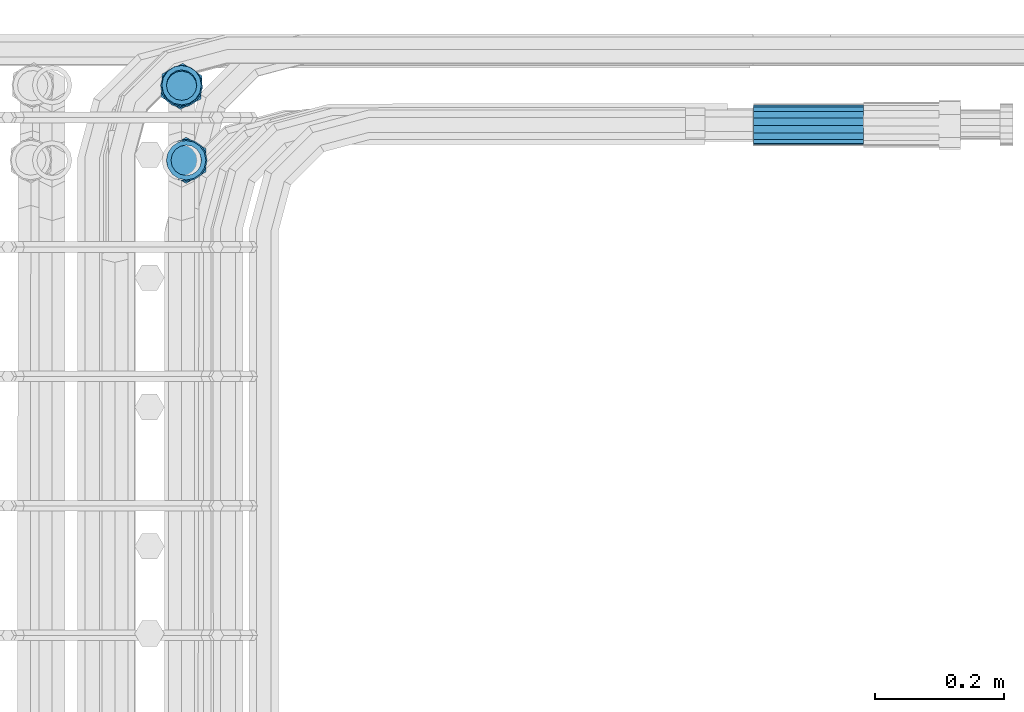
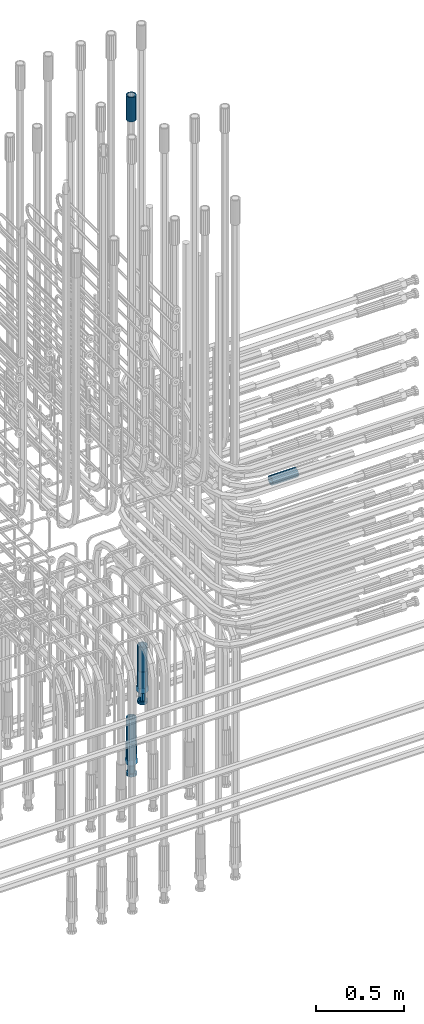
# One storey, part 108 of 177: 6 beams.
"""IFC2X3 building model written with IfcOpenShell, lengths in millimetres."""

from ifc_helpers import new_model, si_unit, frame, origin_with_axes, place, context, subcontext, project, spatial, faceted_brep, material, type_object, element, save


model = new_model("IFC2X3")

# Units and contexts
model_context_1 = context("Model", 3, precision=1e-05, world=origin_with_axes())
model_context_2 = context("Model", 3, precision=1e-05, world=origin_with_axes())
body_context = subcontext(model_context_2, "Body", "Model", "MODEL_VIEW")
ifc_project = project(units=[si_unit("LENGTHUNIT", "METRE", prefix="MILLI"), si_unit("AREAUNIT", "SQUARE_METRE"), si_unit("VOLUMEUNIT", "CUBIC_METRE"), si_unit("MASSUNIT", "GRAM", prefix="KILO"), si_unit("TIMEUNIT", "SECOND"), si_unit("PLANEANGLEUNIT", "RADIAN"), si_unit("SOLIDANGLEUNIT", "STERADIAN"), si_unit("THERMODYNAMICTEMPERATUREUNIT", "DEGREE_CELSIUS"), si_unit("LUMINOUSINTENSITYUNIT", "LUMEN")], contexts=[model_context_1])

# Site, building, storey
site_placement = place(None, origin_with_axes())
site = spatial("IfcSite", under=ifc_project, at=site_placement, CompositionType="ELEMENT")
building_placement = place(site_placement, origin_with_axes())
building = spatial("IfcBuilding", under=site, at=building_placement, Name="Undefined", CompositionType="ELEMENT")
storey_placement = place(building_placement, origin_with_axes())
storey = spatial("IfcBuildingStorey", under=building, at=storey_placement, Name="Undefined", CompositionType="ELEMENT", Elevation=0.0)

# Beams
ifc_material = material(Name="STEEL/S275")
beam_type_1 = type_object("IfcBeamType", PredefinedType="NOTDEFINED")
beam_1_placement = place(storey_placement, frame((2038719.51584447, 6206284.09877293, 19865.9276902425), z_axis=(0.0, 0.0401317930035295, -0.99919439509553), x_axis=(1.0, 0.0, 0.0)))
element("IfcBeam", 1, at=beam_1_placement, inside=storey, type_object=beam_type_1, material=ifc_material, Name="AG40N", context=body_context, shape_type="Brep", body=[
    faceted_brep([(0.0, -23.5000000001164, -9.31322574615479e-10), (0.0, -21.7111690140155, 8.99306066054851), (170.0, -21.7111690140155, 8.99306066054851), (170.0, -23.5, 0.0), (0.0, -16.6170093578839, 16.6170093575493), (170.0, -16.6170093578839, 16.6170093575493), (0.0, -8.99306066057943, 21.7111690137535), (170.0, -8.99306066057943, 21.7111690137535), (0.0, 1.16415321826935e-10, 23.5), (170.0, 0.0, 23.5), (0.0, 8.99306066057943, 21.7111690137535), (170.0, 8.99306066057943, 21.7111690137535), (0.0, 16.6170093578839, 16.6170093575493), (170.0, 16.6170093578839, 16.6170093575493), (0.0, 21.7111690140155, 8.99306066054851), (170.0, 21.7111690140155, 8.99306066054851), (0.0, 23.5000000001164, -9.31322574615479e-10), (170.0, 23.5, 0.0), (0.0, 21.7111690140155, -8.99306066054851), (170.0, 21.7111690140155, -8.99306066054851), (0.0, 16.6170093578839, -16.6170093575493), (170.0, 16.6170093578839, -16.6170093575493), (0.0, 8.99306066057943, -21.7111690137535), (170.0, 8.99306066057943, -21.7111690137535), (0.0, 1.16415321826935e-10, -23.5000000009313), (170.0, 0.0, -23.5), (0.0, -8.99306066057943, -21.7111690137535), (170.0, -8.99306066057943, -21.7111690137535), (0.0, -16.6170093578839, -16.6170093575493), (170.0, -16.6170093578839, -16.6170093575493), (0.0, -21.7111690140155, -8.99306066054851), (170.0, -21.7111690140155, -8.99306066054851), (0.0, -30.5, 0.0), (0.0, -28.1783257415937, -11.6718446873128), (170.0, -28.1783257415937, -11.6718446873128), (170.0, -30.5, 0.0), (0.0, -21.5667568261888, -21.5667568258941), (170.0, -21.5667568261888, -21.5667568258941), (0.0, -11.6718446871346, -28.1783257415518), (170.0, -11.6718446871346, -28.1783257415518), (0.0, 0.0, -30.5), (170.0, 0.0, -30.5), (0.0, 11.6718446871346, -28.1783257415518), (170.0, 11.6718446871346, -28.1783257415518), (0.0, 21.5667568261888, -21.5667568258941), (170.0, 21.5667568261888, -21.5667568258941), (0.0, 28.1783257415937, -11.6718446873128), (170.0, 28.1783257415937, -11.6718446873128), (0.0, 30.5, 0.0), (170.0, 30.5, 0.0), (0.0, 28.1783257415937, 11.6718446873128), (170.0, 28.1783257415937, 11.6718446873128), (0.0, 21.5667568261888, 21.5667568258941), (170.0, 21.5667568261888, 21.5667568258941), (0.0, 11.6718446871346, 28.1783257415518), (170.0, 11.6718446871346, 28.1783257415518), (0.0, 0.0, 30.5), (170.0, 0.0, 30.5), (0.0, -11.6718446871346, 28.1783257415518), (170.0, -11.6718446871346, 28.1783257415518), (0.0, -21.5667568261888, 21.5667568258941), (170.0, -21.5667568261888, 21.5667568258941), (0.0, -28.1783257415937, 11.6718446873128), (170.0, -28.1783257415937, 11.6718446873128)], [[[0, 1, 2, 3]], [[1, 4, 5, 2]], [[4, 6, 7, 5]], [[6, 8, 9, 7]], [[8, 10, 11, 9]], [[10, 12, 13, 11]], [[12, 14, 15, 13]], [[14, 16, 17, 15]], [[16, 18, 19, 17]], [[18, 20, 21, 19]], [[20, 22, 23, 21]], [[22, 24, 25, 23]], [[24, 26, 27, 25]], [[26, 28, 29, 27]], [[28, 30, 31, 29]], [[30, 0, 3, 31]], [[32, 33, 34, 35]], [[33, 36, 37, 34]], [[36, 38, 39, 37]], [[38, 40, 41, 39]], [[40, 42, 43, 41]], [[42, 44, 45, 43]], [[44, 46, 47, 45]], [[46, 48, 49, 47]], [[48, 50, 51, 49]], [[50, 52, 53, 51]], [[52, 54, 55, 53]], [[54, 56, 57, 55]], [[56, 58, 59, 57]], [[58, 60, 61, 59]], [[60, 62, 63, 61]], [[62, 32, 35, 63]], [[37, 39, 41, 43, 45, 47, 49, 51, 53, 55, 57, 59, 61, 63, 35, 34], [5, 7, 9, 11, 13, 15, 17, 19, 21, 23, 25, 27, 29, 31, 3, 2]], [[62, 60, 58, 56, 54, 52, 50, 48, 46, 44, 42, 40, 38, 36, 33, 32], [30, 28, 26, 24, 22, 20, 18, 16, 14, 12, 10, 8, 6, 4, 1, 0]]]),
])
beam_2_placement = place(storey_placement, frame((2037843.07362224, 6206229.3623307, 19061.481520257), z_axis=(-0.999999999985939, 0.0, -5.30300005993874e-06), x_axis=(5.31199963431904e-06, -7.73640020801241e-05, -0.999999996993297)))
element("IfcBeam", 2, at=beam_2_placement, inside=storey, type_object=beam_type_1, material=ifc_material, Name="AG40N", context=body_context, shape_type="Brep", body=[
    faceted_brep([(0.0, -23.5000000001164, -9.31322574615479e-10), (0.0, -21.7111690140155, 8.99306066054851), (170.0, -21.7111690140155, 8.99306066054851), (170.0, -23.5, 0.0), (0.0, -16.6170093578839, 16.6170093575493), (170.0, -16.6170093578839, 16.6170093575493), (0.0, -8.99306066057943, 21.7111690137535), (170.0, -8.99306066057943, 21.7111690137535), (0.0, 1.16415321826935e-10, 23.5), (170.0, 0.0, 23.5), (0.0, 8.99306066057943, 21.7111690137535), (170.0, 8.99306066057943, 21.7111690137535), (0.0, 16.6170093578839, 16.6170093575493), (170.0, 16.6170093578839, 16.6170093575493), (0.0, 21.7111690140155, 8.99306066054851), (170.0, 21.7111690140155, 8.99306066054851), (0.0, 23.5000000001164, -9.31322574615479e-10), (170.0, 23.5, 0.0), (0.0, 21.7111690140155, -8.99306066054851), (170.0, 21.7111690140155, -8.99306066054851), (0.0, 16.6170093578839, -16.6170093575493), (170.0, 16.6170093578839, -16.6170093575493), (0.0, 8.99306066057943, -21.7111690137535), (170.0, 8.99306066057943, -21.7111690137535), (0.0, 1.16415321826935e-10, -23.5000000009313), (170.0, 0.0, -23.5), (0.0, -8.99306066057943, -21.7111690137535), (170.0, -8.99306066057943, -21.7111690137535), (0.0, -16.6170093578839, -16.6170093575493), (170.0, -16.6170093578839, -16.6170093575493), (0.0, -21.7111690140155, -8.99306066054851), (170.0, -21.7111690140155, -8.99306066054851), (0.0, -30.5, 0.0), (0.0, -28.1783257415937, -11.6718446873128), (170.0, -28.1783257415937, -11.6718446873128), (170.0, -30.5, 0.0), (0.0, -21.5667568261888, -21.5667568258941), (170.0, -21.5667568261888, -21.5667568258941), (0.0, -11.6718446871346, -28.1783257415518), (170.0, -11.6718446871346, -28.1783257415518), (0.0, 0.0, -30.5), (170.0, 0.0, -30.5), (0.0, 11.6718446871346, -28.1783257415518), (170.0, 11.6718446871346, -28.1783257415518), (0.0, 21.5667568261888, -21.5667568258941), (170.0, 21.5667568261888, -21.5667568258941), (0.0, 28.1783257415937, -11.6718446873128), (170.0, 28.1783257415937, -11.6718446873128), (0.0, 30.5, 0.0), (170.0, 30.5, 0.0), (0.0, 28.1783257415937, 11.6718446873128), (170.0, 28.1783257415937, 11.6718446873128), (0.0, 21.5667568261888, 21.5667568258941), (170.0, 21.5667568261888, 21.5667568258941), (0.0, 11.6718446871346, 28.1783257415518), (170.0, 11.6718446871346, 28.1783257415518), (0.0, 0.0, 30.5), (170.0, 0.0, 30.5), (0.0, -11.6718446871346, 28.1783257415518), (170.0, -11.6718446871346, 28.1783257415518), (0.0, -21.5667568261888, 21.5667568258941), (170.0, -21.5667568261888, 21.5667568258941), (0.0, -28.1783257415937, 11.6718446873128), (170.0, -28.1783257415937, 11.6718446873128)], [[[0, 1, 2, 3]], [[1, 4, 5, 2]], [[4, 6, 7, 5]], [[6, 8, 9, 7]], [[8, 10, 11, 9]], [[10, 12, 13, 11]], [[12, 14, 15, 13]], [[14, 16, 17, 15]], [[16, 18, 19, 17]], [[18, 20, 21, 19]], [[20, 22, 23, 21]], [[22, 24, 25, 23]], [[24, 26, 27, 25]], [[26, 28, 29, 27]], [[28, 30, 31, 29]], [[30, 0, 3, 31]], [[32, 33, 34, 35]], [[33, 36, 37, 34]], [[36, 38, 39, 37]], [[38, 40, 41, 39]], [[40, 42, 43, 41]], [[42, 44, 45, 43]], [[44, 46, 47, 45]], [[46, 48, 49, 47]], [[48, 50, 51, 49]], [[50, 52, 53, 51]], [[52, 54, 55, 53]], [[54, 56, 57, 55]], [[56, 58, 59, 57]], [[58, 60, 61, 59]], [[60, 62, 63, 61]], [[62, 32, 35, 63]], [[37, 39, 41, 43, 45, 47, 49, 51, 53, 55, 57, 59, 61, 63, 35, 34], [5, 7, 9, 11, 13, 15, 17, 19, 21, 23, 25, 27, 29, 31, 3, 2]], [[62, 60, 58, 56, 54, 52, 50, 48, 46, 44, 42, 40, 38, 36, 33, 32], [30, 28, 26, 24, 22, 20, 18, 16, 14, 12, 10, 8, 6, 4, 1, 0]]]),
])
beam_3_placement = place(storey_placement, frame((2037835.98013835, 6206343.62881172, 18490.9966011765), z_axis=(-0.998629534784913, 0.052335954988374, -8.40971940488068e-06), x_axis=(1.49400028262477e-06, -0.000132179999857224, -0.999999991263108)))
element("IfcBeam", 3, at=beam_3_placement, inside=storey, type_object=beam_type_1, material=ifc_material, Name="AG40N", context=body_context, shape_type="Brep", body=[
    faceted_brep([(0.0, -23.5000000001164, -9.31322574615479e-10), (0.0, -21.7111690140155, 8.99306066054851), (170.0, -21.7111690140155, 8.99306066054851), (170.0, -23.5, 0.0), (0.0, -16.6170093578839, 16.6170093575493), (170.0, -16.6170093578839, 16.6170093575493), (0.0, -8.99306066057943, 21.7111690137535), (170.0, -8.99306066057943, 21.7111690137535), (0.0, 1.16415321826935e-10, 23.5), (170.0, 0.0, 23.5), (0.0, 8.99306066057943, 21.7111690137535), (170.0, 8.99306066057943, 21.7111690137535), (0.0, 16.6170093578839, 16.6170093575493), (170.0, 16.6170093578839, 16.6170093575493), (0.0, 21.7111690140155, 8.99306066054851), (170.0, 21.7111690140155, 8.99306066054851), (0.0, 23.5000000001164, -9.31322574615479e-10), (170.0, 23.5, 0.0), (0.0, 21.7111690140155, -8.99306066054851), (170.0, 21.7111690140155, -8.99306066054851), (0.0, 16.6170093578839, -16.6170093575493), (170.0, 16.6170093578839, -16.6170093575493), (0.0, 8.99306066057943, -21.7111690137535), (170.0, 8.99306066057943, -21.7111690137535), (0.0, 1.16415321826935e-10, -23.5000000009313), (170.0, 0.0, -23.5), (0.0, -8.99306066057943, -21.7111690137535), (170.0, -8.99306066057943, -21.7111690137535), (0.0, -16.6170093578839, -16.6170093575493), (170.0, -16.6170093578839, -16.6170093575493), (0.0, -21.7111690140155, -8.99306066054851), (170.0, -21.7111690140155, -8.99306066054851), (0.0, -30.5, 0.0), (0.0, -28.1783257415937, -11.6718446873128), (170.0, -28.1783257415937, -11.6718446873128), (170.0, -30.5, 0.0), (0.0, -21.5667568261888, -21.5667568258941), (170.0, -21.5667568261888, -21.5667568258941), (0.0, -11.6718446871346, -28.1783257415518), (170.0, -11.6718446871346, -28.1783257415518), (0.0, 0.0, -30.5), (170.0, 0.0, -30.5), (0.0, 11.6718446871346, -28.1783257415518), (170.0, 11.6718446871346, -28.1783257415518), (0.0, 21.5667568261888, -21.5667568258941), (170.0, 21.5667568261888, -21.5667568258941), (0.0, 28.1783257415937, -11.6718446873128), (170.0, 28.1783257415937, -11.6718446873128), (0.0, 30.5, 0.0), (170.0, 30.5, 0.0), (0.0, 28.1783257415937, 11.6718446873128), (170.0, 28.1783257415937, 11.6718446873128), (0.0, 21.5667568261888, 21.5667568258941), (170.0, 21.5667568261888, 21.5667568258941), (0.0, 11.6718446871346, 28.1783257415518), (170.0, 11.6718446871346, 28.1783257415518), (0.0, 0.0, 30.5), (170.0, 0.0, 30.5), (0.0, -11.6718446871346, 28.1783257415518), (170.0, -11.6718446871346, 28.1783257415518), (0.0, -21.5667568261888, 21.5667568258941), (170.0, -21.5667568261888, 21.5667568258941), (0.0, -28.1783257415937, 11.6718446873128), (170.0, -28.1783257415937, 11.6718446873128)], [[[0, 1, 2, 3]], [[1, 4, 5, 2]], [[4, 6, 7, 5]], [[6, 8, 9, 7]], [[8, 10, 11, 9]], [[10, 12, 13, 11]], [[12, 14, 15, 13]], [[14, 16, 17, 15]], [[16, 18, 19, 17]], [[18, 20, 21, 19]], [[20, 22, 23, 21]], [[22, 24, 25, 23]], [[24, 26, 27, 25]], [[26, 28, 29, 27]], [[28, 30, 31, 29]], [[30, 0, 3, 31]], [[32, 33, 34, 35]], [[33, 36, 37, 34]], [[36, 38, 39, 37]], [[38, 40, 41, 39]], [[40, 42, 43, 41]], [[42, 44, 45, 43]], [[44, 46, 47, 45]], [[46, 48, 49, 47]], [[48, 50, 51, 49]], [[50, 52, 53, 51]], [[52, 54, 55, 53]], [[54, 56, 57, 55]], [[56, 58, 59, 57]], [[58, 60, 61, 59]], [[60, 62, 63, 61]], [[62, 32, 35, 63]], [[37, 39, 41, 43, 45, 47, 49, 51, 53, 55, 57, 59, 61, 63, 35, 34], [5, 7, 9, 11, 13, 15, 17, 19, 21, 23, 25, 27, 29, 31, 3, 2]], [[62, 60, 58, 56, 54, 52, 50, 48, 46, 44, 42, 40, 38, 36, 33, 32], [30, 28, 26, 24, 22, 20, 18, 16, 14, 12, 10, 8, 6, 4, 1, 0]]]),
])
beam_4_placement = place(storey_placement, frame((2037836.02583425, 6206345.40964988, 22660.0018034583), z_axis=(1.0, 0.0, 0.0), x_axis=(0.0, 0.0, 1.0)))
element("IfcBeam", 4, at=beam_4_placement, inside=storey, type_object=beam_type_1, material=ifc_material, Name="AG40N", context=body_context, shape_type="Brep", body=[
    faceted_brep([(0.0, -23.5000000001164, -9.31322574615479e-10), (0.0, -21.7111690140155, 8.99306066054851), (170.0, -21.7111690140155, 8.99306066054851), (170.0, -23.5, 0.0), (0.0, -16.6170093578839, 16.6170093575493), (170.0, -16.6170093578839, 16.6170093575493), (0.0, -8.99306066057943, 21.7111690137535), (170.0, -8.99306066057943, 21.7111690137535), (0.0, 1.16415321826935e-10, 23.5), (170.0, 0.0, 23.5), (0.0, 8.99306066057943, 21.7111690137535), (170.0, 8.99306066057943, 21.7111690137535), (0.0, 16.6170093578839, 16.6170093575493), (170.0, 16.6170093578839, 16.6170093575493), (0.0, 21.7111690140155, 8.99306066054851), (170.0, 21.7111690140155, 8.99306066054851), (0.0, 23.5000000001164, -9.31322574615479e-10), (170.0, 23.5, 0.0), (0.0, 21.7111690140155, -8.99306066054851), (170.0, 21.7111690140155, -8.99306066054851), (0.0, 16.6170093578839, -16.6170093575493), (170.0, 16.6170093578839, -16.6170093575493), (0.0, 8.99306066057943, -21.7111690137535), (170.0, 8.99306066057943, -21.7111690137535), (0.0, 1.16415321826935e-10, -23.5000000009313), (170.0, 0.0, -23.5), (0.0, -8.99306066057943, -21.7111690137535), (170.0, -8.99306066057943, -21.7111690137535), (0.0, -16.6170093578839, -16.6170093575493), (170.0, -16.6170093578839, -16.6170093575493), (0.0, -21.7111690140155, -8.99306066054851), (170.0, -21.7111690140155, -8.99306066054851), (0.0, -30.5, 0.0), (0.0, -28.1783257415937, -11.6718446873128), (170.0, -28.1783257415937, -11.6718446873128), (170.0, -30.5, 0.0), (0.0, -21.5667568261888, -21.5667568258941), (170.0, -21.5667568261888, -21.5667568258941), (0.0, -11.6718446871346, -28.1783257415518), (170.0, -11.6718446871346, -28.1783257415518), (0.0, 0.0, -30.5), (170.0, 0.0, -30.5), (0.0, 11.6718446871346, -28.1783257415518), (170.0, 11.6718446871346, -28.1783257415518), (0.0, 21.5667568261888, -21.5667568258941), (170.0, 21.5667568261888, -21.5667568258941), (0.0, 28.1783257415937, -11.6718446873128), (170.0, 28.1783257415937, -11.6718446873128), (0.0, 30.5, 0.0), (170.0, 30.5, 0.0), (0.0, 28.1783257415937, 11.6718446873128), (170.0, 28.1783257415937, 11.6718446873128), (0.0, 21.5667568261888, 21.5667568258941), (170.0, 21.5667568261888, 21.5667568258941), (0.0, 11.6718446871346, 28.1783257415518), (170.0, 11.6718446871346, 28.1783257415518), (0.0, 0.0, 30.5), (170.0, 0.0, 30.5), (0.0, -11.6718446871346, 28.1783257415518), (170.0, -11.6718446871346, 28.1783257415518), (0.0, -21.5667568261888, 21.5667568258941), (170.0, -21.5667568261888, 21.5667568258941), (0.0, -28.1783257415937, 11.6718446873128), (170.0, -28.1783257415937, 11.6718446873128)], [[[0, 1, 2, 3]], [[1, 4, 5, 2]], [[4, 6, 7, 5]], [[6, 8, 9, 7]], [[8, 10, 11, 9]], [[10, 12, 13, 11]], [[12, 14, 15, 13]], [[14, 16, 17, 15]], [[16, 18, 19, 17]], [[18, 20, 21, 19]], [[20, 22, 23, 21]], [[22, 24, 25, 23]], [[24, 26, 27, 25]], [[26, 28, 29, 27]], [[28, 30, 31, 29]], [[30, 0, 3, 31]], [[32, 33, 34, 35]], [[33, 36, 37, 34]], [[36, 38, 39, 37]], [[38, 40, 41, 39]], [[40, 42, 43, 41]], [[42, 44, 45, 43]], [[44, 46, 47, 45]], [[46, 48, 49, 47]], [[48, 50, 51, 49]], [[50, 52, 53, 51]], [[52, 54, 55, 53]], [[54, 56, 57, 55]], [[56, 58, 59, 57]], [[58, 60, 61, 59]], [[60, 62, 63, 61]], [[62, 32, 35, 63]], [[37, 39, 41, 43, 45, 47, 49, 51, 53, 55, 57, 59, 61, 63, 35, 34], [5, 7, 9, 11, 13, 15, 17, 19, 21, 23, 25, 27, 29, 31, 3, 2]], [[62, 60, 58, 56, 54, 52, 50, 48, 46, 44, 42, 40, 38, 36, 33, 32], [30, 28, 26, 24, 22, 20, 18, 16, 14, 12, 10, 8, 6, 4, 1, 0]]]),
])
beam_type_2 = type_object("IfcBeamType", Name="ROD65", PredefinedType="NOTDEFINED")
beam_5_placement = place(storey_placement, frame((2037843.07452379, 6206229.34917784, 18891.4815207682), z_axis=(-0.999999999985939, 0.0, -5.30300005993874e-06), x_axis=(5.31199963431904e-06, -7.73640020801241e-05, -0.999999996993297)))
element("IfcBeam", 5, at=beam_5_placement, inside=storey, type_object=beam_type_2, material=ifc_material, Name="AGB40", ObjectType="ROD65", context=body_context, shape_type="Brep", body=[
    faceted_brep([(117.0, 8.17543110251427, 30.873805644922), (117.0, 17.8250000001863, 30.873805644922), (117.0, 22.0056958701462, 23.6326279877685), (117.0, 12.4372115517035, 30.0260848065373), (117.0, -17.8250000001863, 30.873805644922), (150.200000000186, -17.8250000001863, 30.873805644922), (150.200000000186, 17.8250000001863, 30.873805644922), (117.0, -8.17543110251427, 30.873805644922), (117.0, -12.4372115517035, 30.0260848065373), (117.0, -22.0056958701462, 23.6326279877685), (117.0, -35.6500000003725, 0.0), (150.200000000186, -35.6500000003725, 0.0), (117.0, -30.8443150008097, 8.32369058486074), (117.0, -32.5, 0.0), (117.0, -30.8443150008097, -8.32369058462791), (117.0, -17.8250000001863, -30.873805644922), (150.200000000186, -17.8250000001863, -30.873805644922), (117.0, -22.0056958701462, -23.6326279877685), (117.0, -12.4372115517035, -30.0260848065373), (117.0, -8.17543110251427, -30.873805644922), (117.0, 17.8250000001863, -30.873805644922), (150.200000000186, 17.8250000001863, -30.873805644922), (117.0, 8.17543110251427, -30.873805644922), (117.0, 22.0056958701462, -23.6326279877685), (117.0, 12.4372115517035, -30.0260848065373), (117.0, 35.6500000003725, 0.0), (150.200000000186, 35.6500000003725, 0.0), (117.0, 30.8443150008097, -8.32369058486074), (117.0, 30.8443150008097, 8.32369058462791), (117.0, 32.5, 0.0), (0.0, -22.9809703892097, 22.9809703885621), (0.0, -30.0260848058388, 12.4372115518636), (117.0, -30.0260848067701, 12.4372115519363), (117.0, -22.9809703882784, 22.9809703885112), (-2.3283064365387e-10, 22.9809703892097, -22.9809703885639), (-4.65661287307739e-10, 30.0260848077014, -12.4372115518672), (117.0, 30.0260848067701, -12.4372115519363), (117.0, 22.9809703882784, -22.9809703885112), (-2.3283064365387e-10, -30.0260848067701, -12.4372115518672), (-2.3283064365387e-10, -22.9809703892097, -22.9809703885621), (117.0, -22.9809703882784, -22.9809703885112), (117.0, -30.0260848067701, -12.4372115519363), (-2.3283064365387e-10, -12.4372115507722, 30.0260848066137), (-2.3283064365387e-10, 9.31322574615479e-10, 32.4999999999982), (-2.3283064365387e-10, 12.4372115526348, 30.0260848066137), (0.0, 22.9809703892097, 22.9809703885621), (-2.3283064365387e-10, 30.0260848077014, 12.4372115518636), (-2.3283064365387e-10, 32.5, 0.0), (-2.3283064365387e-10, 12.4372115526348, -30.0260848066173), (-2.3283064365387e-10, 9.31322574615479e-10, -32.5), (-2.3283064365387e-10, -12.4372115517035, -30.0260848066173), (-4.65661287307739e-10, -32.4999999990687, -1.81898940354586e-12), (117.0, 22.9809703882784, 22.9809703885112), (117.0, 30.0260848067701, 12.4372115519363), (117.0, 0.0, -32.5), (117.0, 0.0, 32.5), (150.200000000186, 10.5, -18.1865334794857), (150.200000000186, 0.0, -21.0), (150.200000000186, -10.5, -18.1865334794857), (150.200000000186, -18.18653347902, -10.5), (150.200000000186, -21.0, 0.0), (150.200000000186, -18.18653347902, 10.5), (150.200000000186, -10.5, 18.1865334794857), (150.200000000186, 0.0, 21.0), (150.200000000186, 10.5, 18.1865334794857), (150.200000000186, 18.18653347902, 10.5), (150.200000000186, 21.0, 0.0), (150.200000000186, 18.18653347902, -10.5), (210.980000000447, -10.5, -18.1865334794857), (210.980000000447, 0.0, -21.0), (210.980000000447, -18.18653347902, -10.5), (210.980000000447, -21.0, 0.0), (210.980000000447, -18.18653347902, 10.5), (210.980000000447, -10.5, 18.1865334794857), (210.980000000447, 0.0, 21.0), (210.980000000447, 10.5, 18.1865334794857), (210.980000000447, 18.18653347902, 10.5), (210.980000000447, 21.0, 0.0), (210.980000000447, 18.18653347902, -10.5), (210.980000000447, 10.5, -18.1865334794857), (211.001368442696, -27.7269937992096, -11.491116326768), (211.003082550167, -21.2238094303757, -21.223815418547), (231.002518367059, -21.2131944671273, -21.2132004550658), (231.000804259587, -27.7163788359612, -11.4805013632867), (211.001368440451, -11.4911085031927, -27.7269970395137), (231.000804257343, -11.4804935399443, -27.7163820760325), (210.996487071217, -0.0106065049767494, -30.0106107392348), (230.995922888109, 8.45827162265778e-06, -29.9999957757536), (210.989181586672, 11.46989420522, -27.7269970329944), (230.988617403564, 11.4805091684684, -27.7163820695132), (210.980564180623, 21.2025914648548, -21.2238154064398), (230.979999997515, 21.2132064281031, -21.2132004429586), (210.971946775022, 27.7057703435421, -11.4911163107026), (230.971382591913, 27.7163853067905, -11.4805013472214), (210.96464129175, 29.9893808094785, -0.0106149562634528), (230.964077108642, 29.9999957727268, 7.21774995326996e-09), (210.959759924415, 27.7057638689876, 11.4698863970116), (230.959195741307, 27.7163788322359, 11.4805013604928), (210.958045816944, 21.2025795001537, 21.2025854887906), (230.957481633835, 21.213194463402, 21.2132004522718), (210.95975992666, 11.4698785729706, 27.7057671097573), (230.959195743551, 11.480493536219, 27.7163820732385), (210.964641295894, -0.010623425245285, 29.9893808094785), (230.964077112785, -8.46199691295624e-06, 29.9999957729597), (210.971946780439, -11.4911241354421, 27.705767103238), (230.97138259733, -11.4805091721937, 27.7163820667192), (210.980564186488, -21.2238213950768, 21.2025854766835), (230.980000003379, -21.2132064318284, 21.2132004401647), (210.989181592089, -27.7270002737641, 11.4698863809463), (230.988617408981, -27.7163853105158, 11.4805013444275), (210.996487075361, -30.0106107397005, -0.0106149734929204), (230.995922892253, -29.9999957764521, -1.00117176771164e-08)], [[[0, 1, 2, 3]], [[4, 5, 6, 1, 0, 7]], [[4, 7, 8, 9]], [[10, 11, 5, 4, 9, 12]], [[10, 12, 13, 14]], [[15, 16, 11, 10, 14, 17]], [[15, 17, 18, 19]], [[20, 21, 16, 15, 19, 22]], [[23, 20, 22, 24]], [[25, 26, 21, 20, 23, 27]], [[28, 25, 27, 29]], [[30, 31, 32, 33]], [[34, 35, 36, 37]], [[38, 39, 40, 41]], [[31, 30, 42, 43, 44, 45, 46, 47, 35, 34, 48, 49, 50, 39, 38, 51]], [[46, 45, 52, 53]], [[29, 47, 46, 53, 28]], [[27, 36, 35, 47, 29]], [[23, 37, 36, 27]], [[24, 48, 34, 37, 23]], [[22, 54, 49, 48, 24]], [[19, 54, 22]], [[18, 50, 49, 54, 19]], [[17, 40, 39, 50, 18]], [[14, 41, 40, 17]], [[13, 51, 38, 41, 14]], [[12, 32, 31, 51, 13]], [[9, 33, 32, 12]], [[8, 42, 30, 33, 9]], [[7, 55, 43, 42, 8]], [[0, 55, 7]], [[3, 44, 43, 55, 0]], [[2, 52, 45, 44, 3]], [[28, 53, 52, 2]], [[1, 6, 26, 25, 28, 2]], [[5, 11, 16, 21, 26, 6], [56, 57, 58, 59, 60, 61, 62, 63, 64, 65, 66, 67]], [[68, 58, 57, 69]], [[70, 59, 58, 68]], [[71, 60, 59, 70]], [[72, 61, 60, 71]], [[73, 62, 61, 72]], [[74, 63, 62, 73]], [[75, 64, 63, 74]], [[76, 65, 64, 75]], [[77, 66, 65, 76]], [[78, 67, 66, 77]], [[79, 56, 67, 78]], [[69, 57, 56, 79]], [[80, 81, 82, 83]], [[81, 84, 85, 82]], [[84, 86, 87, 85]], [[86, 88, 89, 87]], [[88, 90, 91, 89]], [[90, 92, 93, 91]], [[92, 94, 95, 93]], [[94, 96, 97, 95]], [[96, 98, 99, 97]], [[98, 100, 101, 99]], [[100, 102, 103, 101]], [[102, 104, 105, 103]], [[104, 106, 107, 105]], [[106, 108, 109, 107]], [[108, 110, 111, 109]], [[82, 85, 87, 89, 91, 93, 95, 97, 99, 101, 103, 105, 107, 109, 111, 83]], [[110, 80, 83, 111]], [[108, 106, 104, 102, 100, 98, 96, 94, 92, 90, 88, 86, 84, 81, 80, 110], [78, 77, 76, 75, 74, 73, 72, 71, 70, 68, 69, 79]]]),
])
beam_6_placement = place(storey_placement, frame((2037835.98039231, 6206343.60634119, 18320.9966026922), z_axis=(-0.998629534784913, 0.052335954988374, -8.40971940488068e-06), x_axis=(1.49400028262477e-06, -0.000132179999857224, -0.999999991263108)))
element("IfcBeam", 6, at=beam_6_placement, inside=storey, type_object=beam_type_2, material=ifc_material, Name="AGB40", ObjectType="ROD65", context=body_context, shape_type="Brep", body=[
    faceted_brep([(117.0, 8.17543110251427, 30.873805644922), (117.0, 17.8250000001863, 30.873805644922), (117.0, 22.0056958701462, 23.6326279877685), (117.0, 12.4372115517035, 30.0260848065373), (117.0, -17.8250000001863, 30.873805644922), (150.200000000186, -17.8250000001863, 30.873805644922), (150.200000000186, 17.8250000001863, 30.873805644922), (117.0, -8.17543110251427, 30.873805644922), (117.0, -12.4372115517035, 30.0260848065373), (117.0, -22.0056958701462, 23.6326279877685), (117.0, -35.6500000003725, 0.0), (150.200000000186, -35.6500000003725, 0.0), (117.0, -30.8443150008097, 8.32369058486074), (117.0, -32.5, 0.0), (117.0, -30.8443150008097, -8.32369058462791), (117.0, -17.8250000001863, -30.873805644922), (150.200000000186, -17.8250000001863, -30.873805644922), (117.0, -22.0056958701462, -23.6326279877685), (117.0, -12.4372115517035, -30.0260848065373), (117.0, -8.17543110251427, -30.873805644922), (117.0, 17.8250000001863, -30.873805644922), (150.200000000186, 17.8250000001863, -30.873805644922), (117.0, 8.17543110251427, -30.873805644922), (117.0, 22.0056958701462, -23.6326279877685), (117.0, 12.4372115517035, -30.0260848065373), (117.0, 35.6500000003725, 0.0), (150.200000000186, 35.6500000003725, 0.0), (117.0, 30.8443150008097, -8.32369058486074), (117.0, 30.8443150008097, 8.32369058462791), (117.0, 32.5, 0.0), (0.0, -22.9809703892097, 22.9809703885621), (0.0, -30.0260848058388, 12.4372115518636), (117.0, -30.0260848067701, 12.4372115519363), (117.0, -22.9809703882784, 22.9809703885112), (-2.3283064365387e-10, 22.9809703892097, -22.9809703885639), (-4.65661287307739e-10, 30.0260848077014, -12.4372115518672), (117.0, 30.0260848067701, -12.4372115519363), (117.0, 22.9809703882784, -22.9809703885112), (-2.3283064365387e-10, -30.0260848067701, -12.4372115518672), (-2.3283064365387e-10, -22.9809703892097, -22.9809703885621), (117.0, -22.9809703882784, -22.9809703885112), (117.0, -30.0260848067701, -12.4372115519363), (-2.3283064365387e-10, -12.4372115507722, 30.0260848066137), (-2.3283064365387e-10, 9.31322574615479e-10, 32.4999999999982), (-2.3283064365387e-10, 12.4372115526348, 30.0260848066137), (0.0, 22.9809703892097, 22.9809703885621), (-2.3283064365387e-10, 30.0260848077014, 12.4372115518636), (-2.3283064365387e-10, 32.5, 0.0), (-2.3283064365387e-10, 12.4372115526348, -30.0260848066173), (-2.3283064365387e-10, 9.31322574615479e-10, -32.5), (-2.3283064365387e-10, -12.4372115517035, -30.0260848066173), (-4.65661287307739e-10, -32.4999999990687, -1.81898940354586e-12), (117.0, 22.9809703882784, 22.9809703885112), (117.0, 30.0260848067701, 12.4372115519363), (117.0, 0.0, -32.5), (117.0, 0.0, 32.5), (150.200000000186, 10.5, -18.1865334794857), (150.200000000186, 0.0, -21.0), (150.200000000186, -10.5, -18.1865334794857), (150.200000000186, -18.18653347902, -10.5), (150.200000000186, -21.0, 0.0), (150.200000000186, -18.18653347902, 10.5), (150.200000000186, -10.5, 18.1865334794857), (150.200000000186, 0.0, 21.0), (150.200000000186, 10.5, 18.1865334794857), (150.200000000186, 18.18653347902, 10.5), (150.200000000186, 21.0, 0.0), (150.200000000186, 18.18653347902, -10.5), (210.980000000447, -10.5, -18.1865334794857), (210.980000000447, 0.0, -21.0), (210.980000000447, -18.18653347902, -10.5), (210.980000000447, -21.0, 0.0), (210.980000000447, -18.18653347902, 10.5), (210.980000000447, -10.5, 18.1865334794857), (210.980000000447, 0.0, 21.0), (210.980000000447, 10.5, 18.1865334794857), (210.980000000447, 18.18653347902, 10.5), (210.980000000447, 21.0, 0.0), (210.980000000447, 18.18653347902, -10.5), (210.980000000447, 10.5, -18.1865334794857), (211.000662925875, -27.7271720711142, -11.4894933789037), (211.001528232326, -21.2239876538515, -21.222192550078), (231.000981244528, -21.2131946953014, -21.2132028283086), (231.000117249689, -27.7163891801611, -11.4804881438613), (210.999199026228, -11.4912867182866, -27.725373968482), (230.998652038434, -11.4804937597364, -27.7163842467126), (210.994029908103, -0.0107847563922405, -30.0089872141834), (230.993482920305, 8.20215791463852e-06, -29.9999974926468), (210.986807829322, 11.4697158802301, -27.7253728723153), (230.986260841524, 11.4805088387802, -27.7163831507787), (210.978632285911, 21.202413039282, -21.2221905253828), (230.978085298113, 21.2132059978321, -21.2132008036133), (210.970747930249, 27.7055918071419, -11.4894907334819), (230.970199295432, 27.7163839573041, -11.4805011362769), (210.964355084008, 29.9892021650448, -0.00898881326429546), (230.963815281626, 29.9999957103282, -1.12224370241165e-07), (210.960427000082, 27.7055851407349, 11.471512888791), (230.959882751205, 27.7163760997355, 11.4804986503441), (210.959561693631, 21.2024007234722, 21.2042120597325), (230.959014705833, 21.2131936820224, 21.213201781502), (210.961890899729, 11.4696997879073, 27.7073934783693), (230.961343911931, 11.4804927464575, 27.716383199906), (210.967060017854, -0.010802173987031, 29.9910067240708), (230.96651303006, -9.21543687582016e-06, 29.9999964458402), (210.974282096635, -11.4913028106093, 27.7073923824355), (230.973735108837, -11.4805098520592, 27.716382104205), (210.982457640042, -21.2239999696612, 21.2042100352701), (230.981910652248, -21.2132070111111, 21.2131997565739), (210.990341995708, -27.7271787375212, 11.4715102433693), (230.989800703082, -27.716385805048, 11.4805017216131), (210.996734841949, -30.0107890954241, -0.00899167661555111), (230.996184719621, -29.9999955575913, -9.73232090473175e-08)], [[[0, 1, 2, 3]], [[4, 5, 6, 1, 0, 7]], [[4, 7, 8, 9]], [[10, 11, 5, 4, 9, 12]], [[10, 12, 13, 14]], [[15, 16, 11, 10, 14, 17]], [[15, 17, 18, 19]], [[20, 21, 16, 15, 19, 22]], [[23, 20, 22, 24]], [[25, 26, 21, 20, 23, 27]], [[28, 25, 27, 29]], [[30, 31, 32, 33]], [[34, 35, 36, 37]], [[38, 39, 40, 41]], [[31, 30, 42, 43, 44, 45, 46, 47, 35, 34, 48, 49, 50, 39, 38, 51]], [[46, 45, 52, 53]], [[29, 47, 46, 53, 28]], [[27, 36, 35, 47, 29]], [[23, 37, 36, 27]], [[24, 48, 34, 37, 23]], [[22, 54, 49, 48, 24]], [[19, 54, 22]], [[18, 50, 49, 54, 19]], [[17, 40, 39, 50, 18]], [[14, 41, 40, 17]], [[13, 51, 38, 41, 14]], [[12, 32, 31, 51, 13]], [[9, 33, 32, 12]], [[8, 42, 30, 33, 9]], [[7, 55, 43, 42, 8]], [[0, 55, 7]], [[3, 44, 43, 55, 0]], [[2, 52, 45, 44, 3]], [[28, 53, 52, 2]], [[1, 6, 26, 25, 28, 2]], [[5, 11, 16, 21, 26, 6], [56, 57, 58, 59, 60, 61, 62, 63, 64, 65, 66, 67]], [[68, 58, 57, 69]], [[70, 59, 58, 68]], [[71, 60, 59, 70]], [[72, 61, 60, 71]], [[73, 62, 61, 72]], [[74, 63, 62, 73]], [[75, 64, 63, 74]], [[76, 65, 64, 75]], [[77, 66, 65, 76]], [[78, 67, 66, 77]], [[79, 56, 67, 78]], [[69, 57, 56, 79]], [[80, 81, 82, 83]], [[81, 84, 85, 82]], [[84, 86, 87, 85]], [[86, 88, 89, 87]], [[88, 90, 91, 89]], [[90, 92, 93, 91]], [[92, 94, 95, 93]], [[94, 96, 97, 95]], [[96, 98, 99, 97]], [[98, 100, 101, 99]], [[100, 102, 103, 101]], [[102, 104, 105, 103]], [[104, 106, 107, 105]], [[106, 108, 109, 107]], [[108, 110, 111, 109]], [[82, 85, 87, 89, 91, 93, 95, 97, 99, 101, 103, 105, 107, 109, 111, 83]], [[110, 80, 83, 111]], [[108, 106, 104, 102, 100, 98, 96, 94, 92, 90, 88, 86, 84, 81, 80, 110], [78, 77, 76, 75, 74, 73, 72, 71, 70, 68, 69, 79]]]),
])

save(model, "model.ifc")
